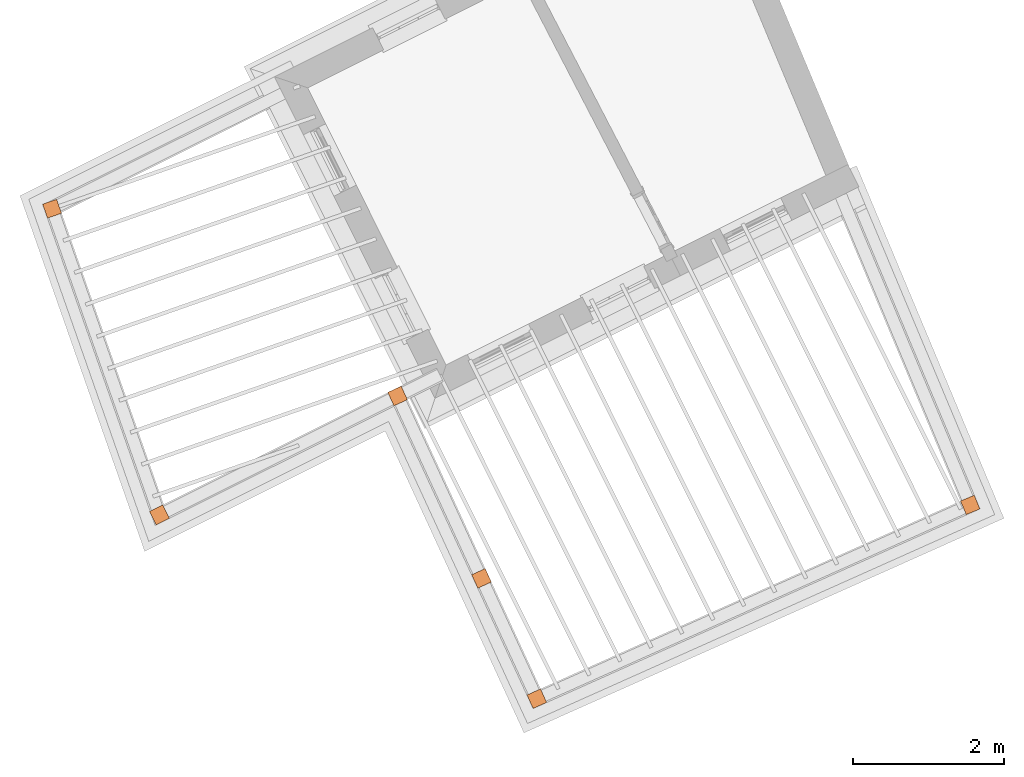
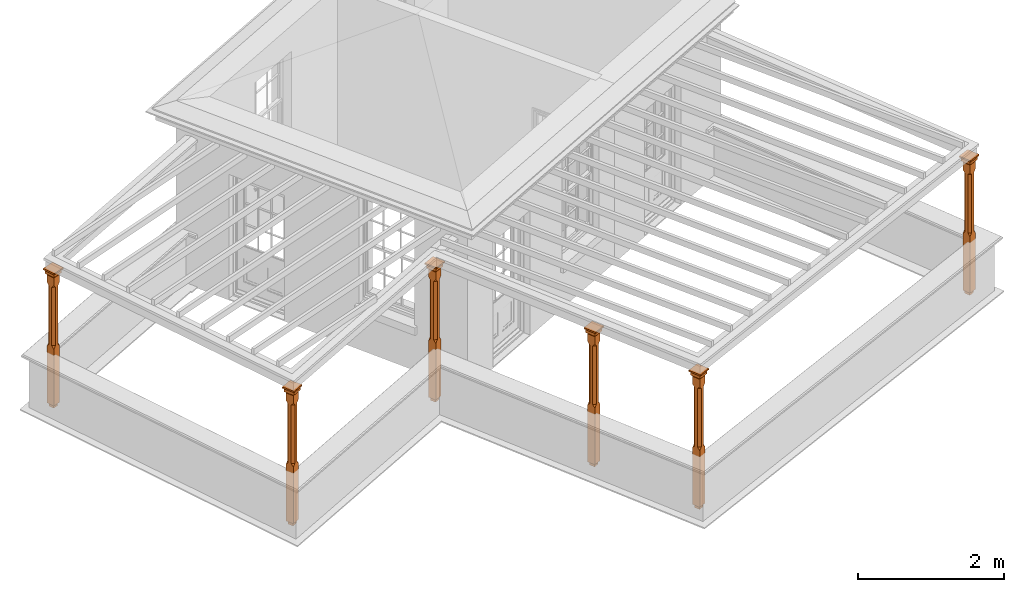
# One storey, part 7 of 7: 6 proxies.
"""IFC2X3 building model written with IfcOpenShell, lengths in metres."""

from ifc_helpers import new_model, si_unit, frame, origin, place, context, subcontext, project, spatial, faceted_brep, element, save


model = new_model("IFC2X3")

# Units and contexts
model_context = context("Model", 3, world=origin())
body_context = subcontext(model_context, "Body", "Model", "MODEL_VIEW")
ifc_project = project(units=[si_unit("PLANEANGLEUNIT", "RADIAN"), si_unit("MASSUNIT", "GRAM", prefix="KILO"), si_unit("FORCEUNIT", "NEWTON", prefix="KILO"), si_unit("LENGTHUNIT", "METRE")], contexts=[model_context])

# Site, building, storey
site_placement = place(None, origin())
site = spatial("IfcSite", under=ifc_project, at=site_placement, CompositionType="ELEMENT")
building_placement = place(None, origin())
building = spatial("IfcBuilding", under=site, at=building_placement, Name="Building plot-8", CompositionType="ELEMENT")
storey_placement = place(None, frame((0.0, 0.0, 6.3)))
storey = spatial("IfcBuildingStorey", under=building, at=storey_placement, Name="Floor 2", CompositionType="ELEMENT", Elevation=6.3)

# Proxies
proxy_1_placement = place(storey_placement, frame((19.2103300053526, 15.5379061141344, 0.0), z_axis=(0.0, 0.0, 1.0), x_axis=(0.330769763437976, -0.943711483237957, 0.0)))
element("IfcBuildingElementProxy", 1, at=proxy_1_placement, inside=storey, Name="pergola post", CompositionType="ELEMENT", context=body_context, shape_type="Brep", held_by="IfcProductRepresentation", body=[
    faceted_brep([(0.0246, -0.0615, 2.02), (0.0615, -0.0246, 2.02), (0.0615, -0.0615, 2.066667), (0.0615, -0.0246, 1.044444), (0.0246, -0.0615, 1.044444), (0.0615, 0.0246, 2.02), (0.0615, 0.0615, 2.066667), (-0.0246, -0.0615, 2.02), (-0.0615, -0.0615, 2.066667), (-0.0246, -0.0615, 1.044444), (0.0615, -0.0615, 0.997778), (0.0615, 0.0246, 1.044444), (0.0246, 0.0615, 2.02), (0.0615, 0.0615, 2.191111), (0.0615, -0.0615, 2.191111), (-0.0615, -0.0615, 2.191111), (-0.0615, -0.0246, 2.02), (-0.0615, -0.0246, 1.044444), (-0.0615, -0.0615, 0.997778), (0.0615, 0.0615, 0.997778), (0.0246, 0.0615, 1.044444), (-0.0246, 0.0615, 2.02), (-0.0615, 0.0615, 2.066667), (0.04305, 0.04305, 2.191111), (0.04305, -0.04305, 2.191111), (-0.0615, 0.0615, 2.191111), (-0.04305, -0.04305, 2.191111), (-0.0615, 0.0246, 2.02), (-0.0615, 0.0246, 1.044444), (0.0615, -0.0615, 0.053333), (-0.0615, -0.0615, 0.053333), (0.0615, 0.0615, 0.053333), (-0.0246, 0.0615, 1.044444), (-0.04305, 0.04305, 2.191111), (0.04305, 0.04305, 2.214444), (0.04305, -0.04305, 2.214444), (-0.04305, -0.04305, 2.214444), (-0.0615, 0.0615, 0.997778), (-0.0615, 0.0615, 0.053333), (-0.04305, -0.04305, 0.053333), (0.04305, -0.04305, 0.053333), (0.04305, 0.04305, 0.053333), (-0.04305, 0.04305, 2.214444), (0.07995, 0.07995, 2.214444), (0.07995, -0.07995, 2.214444), (-0.07995, -0.07995, 2.214444), (-0.04305, 0.04305, 0.053333), (-0.04305, -0.04305, 0.0), (0.04305, -0.04305, 0.0), (0.04305, 0.04305, 0.0), (-0.07995, 0.07995, 2.214444), (0.07995, 0.07995, 2.276667), (0.07995, -0.07995, 2.276667), (-0.07995, -0.07995, 2.276667), (-0.04305, 0.04305, 0.0), (-0.07995, 0.07995, 2.276667), (0.0984, 0.0984, 2.276667), (0.0984, -0.0984, 2.276667), (-0.0984, -0.0984, 2.276667), (-0.0984, 0.0984, 2.276667), (0.0984, 0.0984, 2.3), (0.0984, -0.0984, 2.3), (-0.0984, -0.0984, 2.3), (-0.0984, 0.0984, 2.3)], [[[0, 1, 2]], [[3, 1, 0, 4]], [[1, 5, 6, 2]], [[7, 0, 2, 8]], [[4, 0, 7, 9]], [[3, 4, 10]], [[1, 3, 11, 5]], [[5, 12, 6]], [[13, 14, 2, 6]], [[15, 8, 2, 14]], [[8, 16, 7]], [[9, 7, 16, 17]], [[9, 18, 10, 4]], [[3, 10, 19, 11]], [[20, 12, 5, 11]], [[21, 22, 6, 12]], [[14, 13, 23, 24]], [[13, 6, 22, 25]], [[25, 22, 8, 15]], [[26, 15, 14, 24]], [[16, 8, 22, 27]], [[27, 28, 17, 16]], [[17, 18, 9]], [[29, 10, 18, 30]], [[31, 19, 10, 29]], [[20, 11, 19]], [[12, 20, 32, 21]], [[21, 27, 22]], [[33, 23, 13, 25]], [[23, 34, 35, 24]], [[26, 33, 25, 15]], [[36, 26, 24, 35]], [[28, 27, 21, 32]], [[17, 28, 37, 18]], [[38, 30, 18, 37]], [[29, 30, 39, 40]], [[31, 38, 37, 19]], [[40, 41, 31, 29]], [[32, 20, 19, 37]], [[33, 42, 34, 23]], [[43, 44, 35, 34]], [[42, 33, 26, 36]], [[36, 35, 44, 45]], [[28, 32, 37]], [[46, 39, 30, 38]], [[39, 47, 48, 40]], [[46, 38, 31, 41]], [[49, 41, 40, 48]], [[43, 34, 42, 50]], [[43, 51, 52, 44]], [[45, 50, 42, 36]], [[53, 45, 44, 52]], [[46, 54, 47, 39]], [[54, 46, 41, 49]], [[50, 55, 51, 43]], [[56, 57, 52, 51]], [[55, 50, 45, 53]], [[53, 52, 57, 58]], [[56, 51, 55, 59]], [[56, 60, 61, 57]], [[58, 59, 55, 53]], [[62, 58, 57, 61]], [[59, 63, 60, 56]], [[63, 62, 61, 60]], [[58, 62, 63, 59]], [[47, 54, 49, 48]]]),
])
proxy_2_placement = place(storey_placement, frame((20.6359073827199, 11.4706246090701, 0.0), z_axis=(0.0, 0.0, 1.0), x_axis=(0.89469766112684, 0.446672245806881, 0.0)))
element("IfcBuildingElementProxy", 2, at=proxy_2_placement, inside=storey, Name="pergola post", CompositionType="ELEMENT", context=body_context, shape_type="Brep", held_by="IfcProductRepresentation", body=[
    faceted_brep([(0.0246, -0.0615, 2.02), (0.0615, -0.0246, 2.02), (0.0615, -0.0615, 2.066667), (0.0615, -0.0246, 1.044444), (0.0246, -0.0615, 1.044444), (0.0615, 0.0246, 2.02), (0.0615, 0.0615, 2.066667), (-0.0246, -0.0615, 2.02), (-0.0615, -0.0615, 2.066667), (-0.0246, -0.0615, 1.044444), (0.0615, -0.0615, 0.997778), (0.0615, 0.0246, 1.044444), (0.0246, 0.0615, 2.02), (0.0615, 0.0615, 2.191111), (0.0615, -0.0615, 2.191111), (-0.0615, -0.0615, 2.191111), (-0.0615, -0.0246, 2.02), (-0.0615, -0.0246, 1.044444), (-0.0615, -0.0615, 0.997778), (0.0615, 0.0615, 0.997778), (0.0246, 0.0615, 1.044444), (-0.0246, 0.0615, 2.02), (-0.0615, 0.0615, 2.066667), (0.04305, 0.04305, 2.191111), (0.04305, -0.04305, 2.191111), (-0.0615, 0.0615, 2.191111), (-0.04305, -0.04305, 2.191111), (-0.0615, 0.0246, 2.02), (-0.0615, 0.0246, 1.044444), (0.0615, -0.0615, 0.053333), (-0.0615, -0.0615, 0.053333), (0.0615, 0.0615, 0.053333), (-0.0246, 0.0615, 1.044444), (-0.04305, 0.04305, 2.191111), (0.04305, 0.04305, 2.214444), (0.04305, -0.04305, 2.214444), (-0.04305, -0.04305, 2.214444), (-0.0615, 0.0615, 0.997778), (-0.0615, 0.0615, 0.053333), (-0.04305, -0.04305, 0.053333), (0.04305, -0.04305, 0.053333), (0.04305, 0.04305, 0.053333), (-0.04305, 0.04305, 2.214444), (0.07995, 0.07995, 2.214444), (0.07995, -0.07995, 2.214444), (-0.07995, -0.07995, 2.214444), (-0.04305, 0.04305, 0.053333), (-0.04305, -0.04305, 0.0), (0.04305, -0.04305, 0.0), (0.04305, 0.04305, 0.0), (-0.07995, 0.07995, 2.214444), (0.07995, 0.07995, 2.276667), (0.07995, -0.07995, 2.276667), (-0.07995, -0.07995, 2.276667), (-0.04305, 0.04305, 0.0), (-0.07995, 0.07995, 2.276667), (0.0984, 0.0984, 2.276667), (0.0984, -0.0984, 2.276667), (-0.0984, -0.0984, 2.276667), (-0.0984, 0.0984, 2.276667), (0.0984, 0.0984, 2.3), (0.0984, -0.0984, 2.3), (-0.0984, -0.0984, 2.3), (-0.0984, 0.0984, 2.3)], [[[0, 1, 2]], [[3, 1, 0, 4]], [[1, 5, 6, 2]], [[7, 0, 2, 8]], [[4, 0, 7, 9]], [[3, 4, 10]], [[1, 3, 11, 5]], [[5, 12, 6]], [[13, 14, 2, 6]], [[15, 8, 2, 14]], [[8, 16, 7]], [[9, 7, 16, 17]], [[9, 18, 10, 4]], [[3, 10, 19, 11]], [[20, 12, 5, 11]], [[21, 22, 6, 12]], [[14, 13, 23, 24]], [[13, 6, 22, 25]], [[25, 22, 8, 15]], [[26, 15, 14, 24]], [[16, 8, 22, 27]], [[27, 28, 17, 16]], [[17, 18, 9]], [[29, 10, 18, 30]], [[31, 19, 10, 29]], [[20, 11, 19]], [[12, 20, 32, 21]], [[21, 27, 22]], [[33, 23, 13, 25]], [[23, 34, 35, 24]], [[26, 33, 25, 15]], [[36, 26, 24, 35]], [[28, 27, 21, 32]], [[17, 28, 37, 18]], [[38, 30, 18, 37]], [[29, 30, 39, 40]], [[31, 38, 37, 19]], [[40, 41, 31, 29]], [[32, 20, 19, 37]], [[33, 42, 34, 23]], [[43, 44, 35, 34]], [[42, 33, 26, 36]], [[36, 35, 44, 45]], [[28, 32, 37]], [[46, 39, 30, 38]], [[39, 47, 48, 40]], [[46, 38, 31, 41]], [[49, 41, 40, 48]], [[43, 34, 42, 50]], [[43, 51, 52, 44]], [[45, 50, 42, 36]], [[53, 45, 44, 52]], [[46, 54, 47, 39]], [[54, 46, 41, 49]], [[50, 55, 51, 43]], [[56, 57, 52, 51]], [[55, 50, 45, 53]], [[53, 52, 57, 58]], [[56, 51, 55, 59]], [[56, 60, 61, 57]], [[58, 59, 55, 53]], [[62, 58, 57, 61]], [[59, 63, 60, 56]], [[63, 62, 61, 60]], [[58, 62, 63, 59]], [[47, 54, 49, 48]]]),
])
proxy_3_placement = place(storey_placement, frame((23.7996751591945, 13.0501160052469, 0.0), z_axis=(0.0, 0.0, 1.0), x_axis=(0.417898615670253, -0.90849366922444, 0.0)))
element("IfcBuildingElementProxy", 3, at=proxy_3_placement, inside=storey, Name="pergola post", CompositionType="ELEMENT", context=body_context, shape_type="Brep", held_by="IfcProductRepresentation", body=[
    faceted_brep([(0.0246, -0.0615, 2.02), (0.0615, -0.0246, 2.02), (0.0615, -0.0615, 2.066667), (0.0615, -0.0246, 1.044444), (0.0246, -0.0615, 1.044444), (0.0615, 0.0246, 2.02), (0.0615, 0.0615, 2.066667), (-0.0246, -0.0615, 2.02), (-0.0615, -0.0615, 2.066667), (-0.0246, -0.0615, 1.044444), (0.0615, -0.0615, 0.997778), (0.0615, 0.0246, 1.044444), (0.0246, 0.0615, 2.02), (0.0615, 0.0615, 2.191111), (0.0615, -0.0615, 2.191111), (-0.0615, -0.0615, 2.191111), (-0.0615, -0.0246, 2.02), (-0.0615, -0.0246, 1.044444), (-0.0615, -0.0615, 0.997778), (0.0615, 0.0615, 0.997778), (0.0246, 0.0615, 1.044444), (-0.0246, 0.0615, 2.02), (-0.0615, 0.0615, 2.066667), (0.04305, 0.04305, 2.191111), (0.04305, -0.04305, 2.191111), (-0.0615, 0.0615, 2.191111), (-0.04305, -0.04305, 2.191111), (-0.0615, 0.0246, 2.02), (-0.0615, 0.0246, 1.044444), (0.0615, -0.0615, 0.053333), (-0.0615, -0.0615, 0.053333), (0.0615, 0.0615, 0.053333), (-0.0246, 0.0615, 1.044444), (-0.04305, 0.04305, 2.191111), (0.04305, 0.04305, 2.214444), (0.04305, -0.04305, 2.214444), (-0.04305, -0.04305, 2.214444), (-0.0615, 0.0615, 0.997778), (-0.0615, 0.0615, 0.053333), (-0.04305, -0.04305, 0.053333), (0.04305, -0.04305, 0.053333), (0.04305, 0.04305, 0.053333), (-0.04305, 0.04305, 2.214444), (0.07995, 0.07995, 2.214444), (0.07995, -0.07995, 2.214444), (-0.07995, -0.07995, 2.214444), (-0.04305, 0.04305, 0.053333), (-0.04305, -0.04305, 0.0), (0.04305, -0.04305, 0.0), (0.04305, 0.04305, 0.0), (-0.07995, 0.07995, 2.214444), (0.07995, 0.07995, 2.276667), (0.07995, -0.07995, 2.276667), (-0.07995, -0.07995, 2.276667), (-0.04305, 0.04305, 0.0), (-0.07995, 0.07995, 2.276667), (0.0984, 0.0984, 2.276667), (0.0984, -0.0984, 2.276667), (-0.0984, -0.0984, 2.276667), (-0.0984, 0.0984, 2.276667), (0.0984, 0.0984, 2.3), (0.0984, -0.0984, 2.3), (-0.0984, -0.0984, 2.3), (-0.0984, 0.0984, 2.3)], [[[0, 1, 2]], [[3, 1, 0, 4]], [[1, 5, 6, 2]], [[7, 0, 2, 8]], [[4, 0, 7, 9]], [[3, 4, 10]], [[1, 3, 11, 5]], [[5, 12, 6]], [[13, 14, 2, 6]], [[15, 8, 2, 14]], [[8, 16, 7]], [[9, 7, 16, 17]], [[9, 18, 10, 4]], [[3, 10, 19, 11]], [[20, 12, 5, 11]], [[21, 22, 6, 12]], [[14, 13, 23, 24]], [[13, 6, 22, 25]], [[25, 22, 8, 15]], [[26, 15, 14, 24]], [[16, 8, 22, 27]], [[27, 28, 17, 16]], [[17, 18, 9]], [[29, 10, 18, 30]], [[31, 19, 10, 29]], [[20, 11, 19]], [[12, 20, 32, 21]], [[21, 27, 22]], [[33, 23, 13, 25]], [[23, 34, 35, 24]], [[26, 33, 25, 15]], [[36, 26, 24, 35]], [[28, 27, 21, 32]], [[17, 28, 37, 18]], [[38, 30, 18, 37]], [[29, 30, 39, 40]], [[31, 38, 37, 19]], [[40, 41, 31, 29]], [[32, 20, 19, 37]], [[33, 42, 34, 23]], [[43, 44, 35, 34]], [[42, 33, 26, 36]], [[36, 35, 44, 45]], [[28, 32, 37]], [[46, 39, 30, 38]], [[39, 47, 48, 40]], [[46, 38, 31, 41]], [[49, 41, 40, 48]], [[43, 34, 42, 50]], [[43, 51, 52, 44]], [[45, 50, 42, 36]], [[53, 45, 44, 52]], [[46, 54, 47, 39]], [[54, 46, 41, 49]], [[50, 55, 51, 43]], [[56, 57, 52, 51]], [[55, 50, 45, 53]], [[53, 52, 57, 58]], [[56, 51, 55, 59]], [[56, 60, 61, 57]], [[58, 59, 55, 53]], [[62, 58, 57, 61]], [[59, 63, 60, 56]], [[63, 62, 61, 60]], [[58, 62, 63, 59]], [[47, 54, 49, 48]]]),
])
proxy_4_placement = place(storey_placement, frame((24.9140956803603, 10.6274135832513, 0.0), z_axis=(0.0, 0.0, 1.0), x_axis=(0.417898615670292, -0.908493669224422, 0.0)))
element("IfcBuildingElementProxy", 4, at=proxy_4_placement, inside=storey, Name="pergola post", CompositionType="ELEMENT", context=body_context, shape_type="Brep", held_by="IfcProductRepresentation", body=[
    faceted_brep([(0.0246, -0.0615, 2.02), (0.0615, -0.0246, 2.02), (0.0615, -0.0615, 2.066667), (0.0615, -0.0246, 1.044444), (0.0246, -0.0615, 1.044444), (0.0615, 0.0246, 2.02), (0.0615, 0.0615, 2.066667), (-0.0246, -0.0615, 2.02), (-0.0615, -0.0615, 2.066667), (-0.0246, -0.0615, 1.044444), (0.0615, -0.0615, 0.997778), (0.0615, 0.0246, 1.044444), (0.0246, 0.0615, 2.02), (0.0615, 0.0615, 2.191111), (0.0615, -0.0615, 2.191111), (-0.0615, -0.0615, 2.191111), (-0.0615, -0.0246, 2.02), (-0.0615, -0.0246, 1.044444), (-0.0615, -0.0615, 0.997778), (0.0615, 0.0615, 0.997778), (0.0246, 0.0615, 1.044444), (-0.0246, 0.0615, 2.02), (-0.0615, 0.0615, 2.066667), (0.04305, 0.04305, 2.191111), (0.04305, -0.04305, 2.191111), (-0.0615, 0.0615, 2.191111), (-0.04305, -0.04305, 2.191111), (-0.0615, 0.0246, 2.02), (-0.0615, 0.0246, 1.044444), (0.0615, -0.0615, 0.053333), (-0.0615, -0.0615, 0.053333), (0.0615, 0.0615, 0.053333), (-0.0246, 0.0615, 1.044444), (-0.04305, 0.04305, 2.191111), (0.04305, 0.04305, 2.214444), (0.04305, -0.04305, 2.214444), (-0.04305, -0.04305, 2.214444), (-0.0615, 0.0615, 0.997778), (-0.0615, 0.0615, 0.053333), (-0.04305, -0.04305, 0.053333), (0.04305, -0.04305, 0.053333), (0.04305, 0.04305, 0.053333), (-0.04305, 0.04305, 2.214444), (0.07995, 0.07995, 2.214444), (0.07995, -0.07995, 2.214444), (-0.07995, -0.07995, 2.214444), (-0.04305, 0.04305, 0.053333), (-0.04305, -0.04305, 0.0), (0.04305, -0.04305, 0.0), (0.04305, 0.04305, 0.0), (-0.07995, 0.07995, 2.214444), (0.07995, 0.07995, 2.276667), (0.07995, -0.07995, 2.276667), (-0.07995, -0.07995, 2.276667), (-0.04305, 0.04305, 0.0), (-0.07995, 0.07995, 2.276667), (0.0984, 0.0984, 2.276667), (0.0984, -0.0984, 2.276667), (-0.0984, -0.0984, 2.276667), (-0.0984, 0.0984, 2.276667), (0.0984, 0.0984, 2.3), (0.0984, -0.0984, 2.3), (-0.0984, -0.0984, 2.3), (-0.0984, 0.0984, 2.3)], [[[0, 1, 2]], [[3, 1, 0, 4]], [[1, 5, 6, 2]], [[7, 0, 2, 8]], [[4, 0, 7, 9]], [[3, 4, 10]], [[1, 3, 11, 5]], [[5, 12, 6]], [[13, 14, 2, 6]], [[15, 8, 2, 14]], [[8, 16, 7]], [[9, 7, 16, 17]], [[9, 18, 10, 4]], [[3, 10, 19, 11]], [[20, 12, 5, 11]], [[21, 22, 6, 12]], [[14, 13, 23, 24]], [[13, 6, 22, 25]], [[25, 22, 8, 15]], [[26, 15, 14, 24]], [[16, 8, 22, 27]], [[27, 28, 17, 16]], [[17, 18, 9]], [[29, 10, 18, 30]], [[31, 19, 10, 29]], [[20, 11, 19]], [[12, 20, 32, 21]], [[21, 27, 22]], [[33, 23, 13, 25]], [[23, 34, 35, 24]], [[26, 33, 25, 15]], [[36, 26, 24, 35]], [[28, 27, 21, 32]], [[17, 28, 37, 18]], [[38, 30, 18, 37]], [[29, 30, 39, 40]], [[31, 38, 37, 19]], [[40, 41, 31, 29]], [[32, 20, 19, 37]], [[33, 42, 34, 23]], [[43, 44, 35, 34]], [[42, 33, 26, 36]], [[36, 35, 44, 45]], [[28, 32, 37]], [[46, 39, 30, 38]], [[39, 47, 48, 40]], [[46, 38, 31, 41]], [[49, 41, 40, 48]], [[43, 34, 42, 50]], [[43, 51, 52, 44]], [[45, 50, 42, 36]], [[53, 45, 44, 52]], [[46, 54, 47, 39]], [[54, 46, 41, 49]], [[50, 55, 51, 43]], [[56, 57, 52, 51]], [[55, 50, 45, 53]], [[53, 52, 57, 58]], [[56, 51, 55, 59]], [[56, 60, 61, 57]], [[58, 59, 55, 53]], [[62, 58, 57, 61]], [[59, 63, 60, 56]], [[63, 62, 61, 60]], [[58, 62, 63, 59]], [[47, 54, 49, 48]]]),
])
proxy_5_placement = place(storey_placement, frame((25.6491830633519, 9.02936513625309, 0.0), z_axis=(0.0, 0.0, 1.0), x_axis=(0.912936483111723, 0.408101675815719, 0.0)))
element("IfcBuildingElementProxy", 5, at=proxy_5_placement, inside=storey, Name="pergola post", CompositionType="ELEMENT", context=body_context, shape_type="Brep", held_by="IfcProductRepresentation", body=[
    faceted_brep([(0.0246, -0.0615, 2.02), (0.0615, -0.0246, 2.02), (0.0615, -0.0615, 2.066667), (0.0615, -0.0246, 1.044444), (0.0246, -0.0615, 1.044444), (0.0615, 0.0246, 2.02), (0.0615, 0.0615, 2.066667), (-0.0246, -0.0615, 2.02), (-0.0615, -0.0615, 2.066667), (-0.0246, -0.0615, 1.044444), (0.0615, -0.0615, 0.997778), (0.0615, 0.0246, 1.044444), (0.0246, 0.0615, 2.02), (0.0615, 0.0615, 2.191111), (0.0615, -0.0615, 2.191111), (-0.0615, -0.0615, 2.191111), (-0.0615, -0.0246, 2.02), (-0.0615, -0.0246, 1.044444), (-0.0615, -0.0615, 0.997778), (0.0615, 0.0615, 0.997778), (0.0246, 0.0615, 1.044444), (-0.0246, 0.0615, 2.02), (-0.0615, 0.0615, 2.066667), (0.04305, 0.04305, 2.191111), (0.04305, -0.04305, 2.191111), (-0.0615, 0.0615, 2.191111), (-0.04305, -0.04305, 2.191111), (-0.0615, 0.0246, 2.02), (-0.0615, 0.0246, 1.044444), (0.0615, -0.0615, 0.053333), (-0.0615, -0.0615, 0.053333), (0.0615, 0.0615, 0.053333), (-0.0246, 0.0615, 1.044444), (-0.04305, 0.04305, 2.191111), (0.04305, 0.04305, 2.214444), (0.04305, -0.04305, 2.214444), (-0.04305, -0.04305, 2.214444), (-0.0615, 0.0615, 0.997778), (-0.0615, 0.0615, 0.053333), (-0.04305, -0.04305, 0.053333), (0.04305, -0.04305, 0.053333), (0.04305, 0.04305, 0.053333), (-0.04305, 0.04305, 2.214444), (0.07995, 0.07995, 2.214444), (0.07995, -0.07995, 2.214444), (-0.07995, -0.07995, 2.214444), (-0.04305, 0.04305, 0.053333), (-0.04305, -0.04305, 0.0), (0.04305, -0.04305, 0.0), (0.04305, 0.04305, 0.0), (-0.07995, 0.07995, 2.214444), (0.07995, 0.07995, 2.276667), (0.07995, -0.07995, 2.276667), (-0.07995, -0.07995, 2.276667), (-0.04305, 0.04305, 0.0), (-0.07995, 0.07995, 2.276667), (0.0984, 0.0984, 2.276667), (0.0984, -0.0984, 2.276667), (-0.0984, -0.0984, 2.276667), (-0.0984, 0.0984, 2.276667), (0.0984, 0.0984, 2.3), (0.0984, -0.0984, 2.3), (-0.0984, -0.0984, 2.3), (-0.0984, 0.0984, 2.3)], [[[0, 1, 2]], [[3, 1, 0, 4]], [[1, 5, 6, 2]], [[7, 0, 2, 8]], [[4, 0, 7, 9]], [[3, 4, 10]], [[1, 3, 11, 5]], [[5, 12, 6]], [[13, 14, 2, 6]], [[15, 8, 2, 14]], [[8, 16, 7]], [[9, 7, 16, 17]], [[9, 18, 10, 4]], [[3, 10, 19, 11]], [[20, 12, 5, 11]], [[21, 22, 6, 12]], [[14, 13, 23, 24]], [[13, 6, 22, 25]], [[25, 22, 8, 15]], [[26, 15, 14, 24]], [[16, 8, 22, 27]], [[27, 28, 17, 16]], [[17, 18, 9]], [[29, 10, 18, 30]], [[31, 19, 10, 29]], [[20, 11, 19]], [[12, 20, 32, 21]], [[21, 27, 22]], [[33, 23, 13, 25]], [[23, 34, 35, 24]], [[26, 33, 25, 15]], [[36, 26, 24, 35]], [[28, 27, 21, 32]], [[17, 28, 37, 18]], [[38, 30, 18, 37]], [[29, 30, 39, 40]], [[31, 38, 37, 19]], [[40, 41, 31, 29]], [[32, 20, 19, 37]], [[33, 42, 34, 23]], [[43, 44, 35, 34]], [[42, 33, 26, 36]], [[36, 35, 44, 45]], [[28, 32, 37]], [[46, 39, 30, 38]], [[39, 47, 48, 40]], [[46, 38, 31, 41]], [[49, 41, 40, 48]], [[43, 34, 42, 50]], [[43, 51, 52, 44]], [[45, 50, 42, 36]], [[53, 45, 44, 52]], [[46, 54, 47, 39]], [[54, 46, 41, 49]], [[50, 55, 51, 43]], [[56, 57, 52, 51]], [[55, 50, 45, 53]], [[53, 52, 57, 58]], [[56, 51, 55, 59]], [[56, 60, 61, 57]], [[58, 59, 55, 53]], [[62, 58, 57, 61]], [[59, 63, 60, 56]], [[63, 62, 61, 60]], [[58, 62, 63, 59]], [[47, 54, 49, 48]]]),
])
proxy_6_placement = place(storey_placement, frame((31.4063653367344, 11.6029458586881, 0.0), z_axis=(0.0, 0.0, 1.0), x_axis=(-0.385847817584112, 0.922562443233832, 0.0)))
element("IfcBuildingElementProxy", 6, at=proxy_6_placement, inside=storey, Name="pergola post", CompositionType="ELEMENT", context=body_context, shape_type="Brep", held_by="IfcProductRepresentation", body=[
    faceted_brep([(0.0246, -0.0615, 2.02), (0.0615, -0.0246, 2.02), (0.0615, -0.0615, 2.066667), (0.0615, -0.0246, 1.044444), (0.0246, -0.0615, 1.044444), (0.0615, 0.0246, 2.02), (0.0615, 0.0615, 2.066667), (-0.0246, -0.0615, 2.02), (-0.0615, -0.0615, 2.066667), (-0.0246, -0.0615, 1.044444), (0.0615, -0.0615, 0.997778), (0.0615, 0.0246, 1.044444), (0.0246, 0.0615, 2.02), (0.0615, 0.0615, 2.191111), (0.0615, -0.0615, 2.191111), (-0.0615, -0.0615, 2.191111), (-0.0615, -0.0246, 2.02), (-0.0615, -0.0246, 1.044444), (-0.0615, -0.0615, 0.997778), (0.0615, 0.0615, 0.997778), (0.0246, 0.0615, 1.044444), (-0.0246, 0.0615, 2.02), (-0.0615, 0.0615, 2.066667), (0.04305, 0.04305, 2.191111), (0.04305, -0.04305, 2.191111), (-0.0615, 0.0615, 2.191111), (-0.04305, -0.04305, 2.191111), (-0.0615, 0.0246, 2.02), (-0.0615, 0.0246, 1.044444), (0.0615, -0.0615, 0.053333), (-0.0615, -0.0615, 0.053333), (0.0615, 0.0615, 0.053333), (-0.0246, 0.0615, 1.044444), (-0.04305, 0.04305, 2.191111), (0.04305, 0.04305, 2.214444), (0.04305, -0.04305, 2.214444), (-0.04305, -0.04305, 2.214444), (-0.0615, 0.0615, 0.997778), (-0.0615, 0.0615, 0.053333), (-0.04305, -0.04305, 0.053333), (0.04305, -0.04305, 0.053333), (0.04305, 0.04305, 0.053333), (-0.04305, 0.04305, 2.214444), (0.07995, 0.07995, 2.214444), (0.07995, -0.07995, 2.214444), (-0.07995, -0.07995, 2.214444), (-0.04305, 0.04305, 0.053333), (-0.04305, -0.04305, 0.0), (0.04305, -0.04305, 0.0), (0.04305, 0.04305, 0.0), (-0.07995, 0.07995, 2.214444), (0.07995, 0.07995, 2.276667), (0.07995, -0.07995, 2.276667), (-0.07995, -0.07995, 2.276667), (-0.04305, 0.04305, 0.0), (-0.07995, 0.07995, 2.276667), (0.0984, 0.0984, 2.276667), (0.0984, -0.0984, 2.276667), (-0.0984, -0.0984, 2.276667), (-0.0984, 0.0984, 2.276667), (0.0984, 0.0984, 2.3), (0.0984, -0.0984, 2.3), (-0.0984, -0.0984, 2.3), (-0.0984, 0.0984, 2.3)], [[[0, 1, 2]], [[3, 1, 0, 4]], [[1, 5, 6, 2]], [[7, 0, 2, 8]], [[4, 0, 7, 9]], [[3, 4, 10]], [[1, 3, 11, 5]], [[5, 12, 6]], [[13, 14, 2, 6]], [[15, 8, 2, 14]], [[8, 16, 7]], [[9, 7, 16, 17]], [[9, 18, 10, 4]], [[3, 10, 19, 11]], [[20, 12, 5, 11]], [[21, 22, 6, 12]], [[14, 13, 23, 24]], [[13, 6, 22, 25]], [[25, 22, 8, 15]], [[26, 15, 14, 24]], [[16, 8, 22, 27]], [[27, 28, 17, 16]], [[17, 18, 9]], [[29, 10, 18, 30]], [[31, 19, 10, 29]], [[20, 11, 19]], [[12, 20, 32, 21]], [[21, 27, 22]], [[33, 23, 13, 25]], [[23, 34, 35, 24]], [[26, 33, 25, 15]], [[36, 26, 24, 35]], [[28, 27, 21, 32]], [[17, 28, 37, 18]], [[38, 30, 18, 37]], [[29, 30, 39, 40]], [[31, 38, 37, 19]], [[40, 41, 31, 29]], [[32, 20, 19, 37]], [[33, 42, 34, 23]], [[43, 44, 35, 34]], [[42, 33, 26, 36]], [[36, 35, 44, 45]], [[28, 32, 37]], [[46, 39, 30, 38]], [[39, 47, 48, 40]], [[46, 38, 31, 41]], [[49, 41, 40, 48]], [[43, 34, 42, 50]], [[43, 51, 52, 44]], [[45, 50, 42, 36]], [[53, 45, 44, 52]], [[46, 54, 47, 39]], [[54, 46, 41, 49]], [[50, 55, 51, 43]], [[56, 57, 52, 51]], [[55, 50, 45, 53]], [[53, 52, 57, 58]], [[56, 51, 55, 59]], [[56, 60, 61, 57]], [[58, 59, 55, 53]], [[62, 58, 57, 61]], [[59, 63, 60, 56]], [[63, 62, 61, 60]], [[58, 62, 63, 59]], [[47, 54, 49, 48]]]),
])

save(model, "model.ifc")
